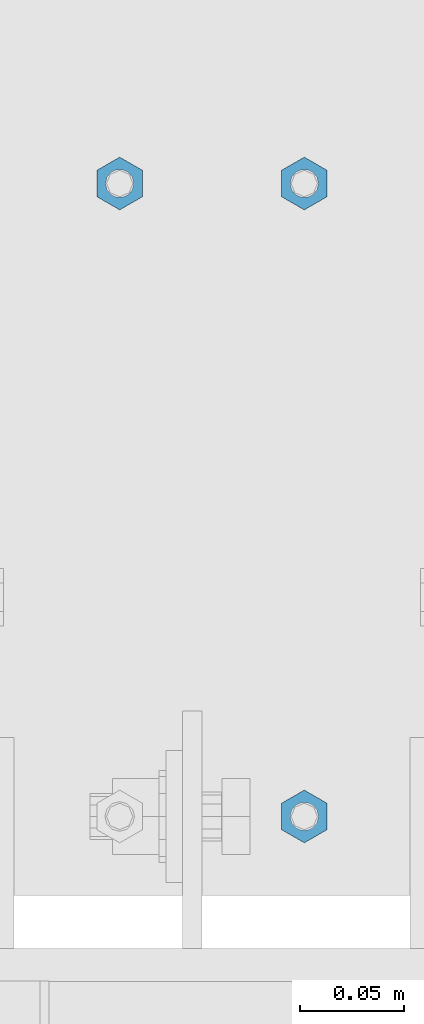
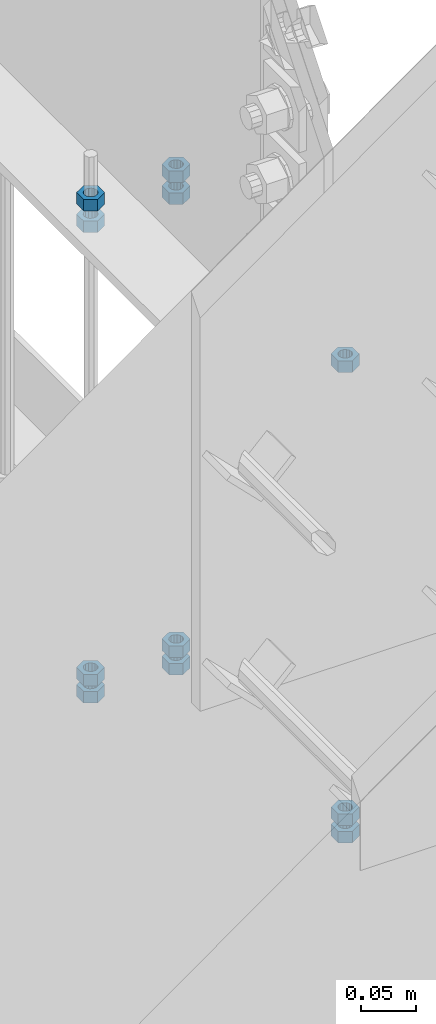
# One storey, part 292 of 975: 11 columns.
"""IFC2X3 building model written with IfcOpenShell, lengths in millimetres."""

import ifcopenshell
import ifcopenshell.guid

model = None  # the IFC model being written
_history = None  # IfcOwnerHistory: only IFC2X3 demands one
_inside = {}  # id of a spatial element -> (the spatial element, [elements in it])
_under = {}  # id of a project, library or spatial element -> (it, [spatial elements below it])
_declared = {}  # id of a project -> (the project, [libraries it declares])
_typed = {}  # id of a type object -> (the type object, [elements of that type])
_made_of = {}  # id of a material, layer set ... -> (it, [elements and type objects made of it])


def new_model(schema):
    """Start an empty IFC model of exactly this schema.

    Asked for "IFC4X3", IfcOpenShell would pick the latest addendum, in which some entities
    have other attributes; the version numbers below select the first issue.
    IFC2X3 requires an IfcOwnerHistory on every rooted entity: one is made here for all.
    """
    global model, _history
    if schema == "IFC4X3":
        model = ifcopenshell.file(schema_version=(4, 3, 0, 0))
    else:
        model = ifcopenshell.file(schema=schema)
    _inside.clear()
    _under.clear()
    _declared.clear()
    _typed.clear()
    _made_of.clear()
    _history = None
    if model.schema == "IFC2X3":
        org = make("IfcOrganization", Name="unknown")
        user = make(
            "IfcPersonAndOrganization",
            ThePerson=make("IfcPerson", FamilyName="unknown"),
            TheOrganization=org,
        )
        app = make(
            "IfcApplication",
            ApplicationDeveloper=org,
            Version="unknown",
            ApplicationFullName="unknown",
            ApplicationIdentifier="unknown",
        )
        _history = make(
            "IfcOwnerHistory",
            OwningUser=user,
            OwningApplication=app,
            ChangeAction="ADDED",
            CreationDate=0,
        )
    return model


def make(cls, **values):
    """One entity of the class cls with the attributes given. An attribute that is None is left unset."""
    return model.create_entity(
        cls, **{name: value for name, value in values.items() if value is not None}
    )


def rooted(cls, **values):
    """An entity with a GlobalId (a new one), such as an element, a storey or a relation."""
    return make(cls, GlobalId=ifcopenshell.guid.new(), OwnerHistory=_history, **values)


def si_unit(unit_type, name, prefix=None):
    """IfcSIUnit, for example si_unit("LENGTHUNIT", "METRE", prefix="MILLI")."""
    return make("IfcSIUnit", UnitType=unit_type, Prefix=prefix, Name=name)


def assignment(units):
    """IfcUnitAssignment: the units of a project."""
    return None if units is None else make("IfcUnitAssignment", Units=units)


def point(xyz):
    """IfcCartesianPoint."""
    return None if xyz is None else make("IfcCartesianPoint", Coordinates=xyz)


def direction(xyz):
    """IfcDirection."""
    return None if xyz is None else make("IfcDirection", DirectionRatios=xyz)


def frame(location, z_axis=None, x_axis=None):
    """IfcAxis2Placement3D, a coordinate frame: its origin and axes. An axis left out is left unset."""
    return make(
        "IfcAxis2Placement3D",
        Location=point(location),
        Axis=direction(z_axis),
        RefDirection=direction(x_axis),
    )


def origin_with_axes():
    """The frame at (0, 0, 0) with the z axis (0, 0, 1) and the x axis (1, 0, 0) written out."""
    return frame((0.0, 0.0, 0.0), z_axis=(0.0, 0.0, 1.0), x_axis=(1.0, 0.0, 0.0))


def place(relative_to, where):
    """IfcLocalPlacement: puts the frame where relative to a parent placement (None: the world)."""
    return make(
        "IfcLocalPlacement", PlacementRelTo=relative_to, RelativePlacement=where
    )


def context(
    kind, dimensions, precision=None, world=None, true_north=None, identifier=None
):
    """IfcGeometricRepresentationContext, for example the 3D "Model" context."""
    return make(
        "IfcGeometricRepresentationContext",
        ContextIdentifier=identifier,
        ContextType=kind,
        CoordinateSpaceDimension=dimensions,
        Precision=precision,
        WorldCoordinateSystem=world,
        TrueNorth=true_north,
    )


def subcontext(parent, identifier, kind, view, scale=None):
    """IfcGeometricRepresentationSubContext, for example "Body" below "Model"."""
    return make(
        "IfcGeometricRepresentationSubContext",
        ContextIdentifier=identifier,
        ContextType=kind,
        ParentContext=parent,
        TargetScale=scale,
        TargetView=view,
    )


def project(units=None, contexts=None):
    """IfcProject with its units and contexts."""
    return rooted(
        "IfcProject",
        Name="project",
        RepresentationContexts=contexts,
        UnitsInContext=assignment(units),
    )


def spatial(cls, under=None, at=None, **own):
    """A site, building, storey or space (cls), placed at a placement, below another one or the project."""
    s = rooted(cls, ObjectPlacement=at, **own)
    if under is not None:
        _under.setdefault(under.id(), (under, []))[1].append(s)
    return s


def faces_of(points, faces, orient=None, outer=None):
    """IfcFace entities. A face is a list of loops; a loop is a list of indices into points, from 0.

    orient and outer hold one flag for each loop. By default every Orientation is true, the
    first loop of a face is its IfcFaceOuterBound and the others are IfcFaceBound.
    """
    made = []
    for i, loops in enumerate(faces):
        bounds = []
        for j, loop in enumerate(loops):
            is_outer = j == 0 if outer is None else outer[i][j]
            bounds.append(
                make(
                    "IfcFaceOuterBound" if is_outer else "IfcFaceBound",
                    Bound=make("IfcPolyLoop", Polygon=[points[k] for k in loop]),
                    Orientation=True if orient is None else orient[i][j],
                )
            )
        made.append(make("IfcFace", Bounds=bounds))
    return made


def faceted_brep(points, faces, orient=None, outer=None, voids=None):
    """IfcFacetedBrep: a solid bounded by flat faces; with voids (closed shells), ...WithVoids."""
    shared = [point(p) for p in points]
    hull = make("IfcClosedShell", CfsFaces=faces_of(shared, faces, orient, outer))
    if voids is None:
        return make("IfcFacetedBrep", Outer=hull)
    return make(
        "IfcFacetedBrepWithVoids",
        Outer=hull,
        Voids=[
            make(cls, CfsFaces=faces_of(shared, fs, o, b)) for cls, fs, o, b in voids
        ],
    )


def shape(context_of_items, identifier, shape_type, items):
    """IfcShapeRepresentation: the items that make up one representation, for example the "Body"."""
    return make(
        "IfcShapeRepresentation",
        ContextOfItems=context_of_items,
        RepresentationIdentifier=identifier,
        RepresentationType=shape_type,
        Items=items,
    )


def material(Name=None, Category=None):
    """IfcMaterial."""
    return make("IfcMaterial", Name=Name, Category=Category)


def made_of(thing, what):
    """Note that an element or type object is made of a material, layer set ...; save() writes the relation."""
    if what is not None:
        _made_of.setdefault(what.id(), (what, []))[1].append(thing)
    return thing


def type_object(cls, material=None, **own):
    """A type object (cls), such as IfcWallType, which elements share."""
    return made_of(rooted(cls, **own), material)


def element(
    cls,
    number,
    at=None,
    inside=None,
    cuts=None,
    type_object=None,
    material=None,
    context=None,
    identifier="Body",
    shape_type=None,
    held_by="IfcProductDefinitionShape",
    body=None,
    shapes=None,
    **own,
):
    """One element of the class cls, such as IfcWall. Its Tag is "e" and its number.

    at: its placement. inside: the storey or other place that contains it. cuts: it is an
    opening in that element (IfcRelVoidsElement). A single representation is given by context,
    identifier, shape_type and body (its items); several are given by shapes. held_by: the class
    of the entity that holds the representations. save() writes the other relations.
    """
    e = rooted(cls, Tag="e%d" % number, ObjectPlacement=at, **own)
    if body is not None:
        shapes = [shape(context, identifier, shape_type, body)]
    if shapes is not None:
        e.Representation = make(held_by, Representations=shapes)
    if inside is not None:
        _inside.setdefault(inside.id(), (inside, []))[1].append(e)
    if cuts is not None:
        rooted(
            "IfcRelVoidsElement", RelatingBuildingElement=cuts, RelatedOpeningElement=e
        )
    if type_object is not None:
        _typed.setdefault(type_object.id(), (type_object, []))[1].append(e)
    return made_of(e, material)


def aggregate(whole, parts):
    """IfcRelAggregates: a whole, such as a stair, and the parts it consists of."""
    return rooted("IfcRelAggregates", RelatingObject=whole, RelatedObjects=parts)


def save(model, path):
    """Write the relations noted so far, then the file.

    IfcRelAggregates (storeys below a building ...), IfcRelContainedInSpatialStructure (elements
    in a storey), IfcRelDefinesByType, IfcRelAssociatesMaterial and IfcRelDeclares: one each for
    every whole, place, type object, material and project.
    """
    for whole, parts in _under.values():
        aggregate(whole, parts)
    for where, things in _inside.values():
        rooted(
            "IfcRelContainedInSpatialStructure",
            RelatedElements=things,
            RelatingStructure=where,
        )
    for kind, things in _typed.values():
        rooted("IfcRelDefinesByType", RelatedObjects=things, RelatingType=kind)
    for what, things in _made_of.values():
        rooted("IfcRelAssociatesMaterial", RelatedObjects=things, RelatingMaterial=what)
    for by, libraries in _declared.values():
        rooted("IfcRelDeclares", RelatingContext=by, RelatedDefinitions=libraries)
    model.write(path)


model = new_model("IFC2X3")

# Units and contexts
model_context = context("Model", 3, precision=1e-05, world=origin_with_axes())
body_context = subcontext(model_context, "Body", "Model", "MODEL_VIEW")
ifc_project = project(units=[si_unit("LENGTHUNIT", "METRE", prefix="MILLI"), si_unit("AREAUNIT", "SQUARE_METRE"), si_unit("VOLUMEUNIT", "CUBIC_METRE"), si_unit("MASSUNIT", "GRAM", prefix="KILO"), si_unit("TIMEUNIT", "SECOND"), si_unit("PLANEANGLEUNIT", "RADIAN"), si_unit("SOLIDANGLEUNIT", "STERADIAN"), si_unit("THERMODYNAMICTEMPERATUREUNIT", "DEGREE_CELSIUS"), si_unit("LUMINOUSINTENSITYUNIT", "LUMEN")], contexts=[model_context])

# Site, building, storey
site_placement = place(None, origin_with_axes())
site = spatial("IfcSite", under=ifc_project, at=site_placement, CompositionType="ELEMENT")
building_placement = place(site_placement, origin_with_axes())
building = spatial("IfcBuilding", under=site, at=building_placement, Name="Undefined", CompositionType="ELEMENT")
storey_placement = place(building_placement, origin_with_axes())
storey = spatial("IfcBuildingStorey", under=building, at=storey_placement, Name="Undefined", CompositionType="ELEMENT", Elevation=0.0)

# Columns
ifc_material = material(Name="STEEL/A307")
column_type = type_object("IfcColumnType", Name="1/2_HEAVY_HEX_NUT", PredefinedType="NOTDEFINED")
column_1_placement = place(storey_placement, frame((8274.05, 21116.925, 2901.95), z_axis=(-0.999999999999998, 6.90000001668524e-08, 0.0), x_axis=(0.0, 0.0, 1.0)))
element("IfcColumn", 1, at=column_1_placement, inside=storey, type_object=column_type, material=ifc_material, Name="NUT", ObjectType="1/2_HEAVY_HEX_NUT", context=body_context, shape_type="Brep", body=[
    faceted_brep([(0.0, -12.6999998092506, -1.09139364212751e-11), (0.0, -6.34999990461802, -11.0000000000218), (12.6999999999998, -6.34999990461802, -11.0000000000218), (12.6999999999998, -12.6999998092506, -1.09139364212751e-11), (0.0, 6.34999990463257, -11.0000000000109), (12.6999999999998, 6.34999990463257, -11.0000000000109), (0.0, 12.6999998092506, 1.09139364212751e-11), (12.6999999999998, 12.6999998092506, 1.09139364212751e-11), (0.0, 6.34999990461802, 11.0000000000218), (12.6999999999998, 6.34999990461802, 11.0000000000218), (0.0, -6.34999990463984, 11.0000000000109), (12.6999999999998, -6.34999990463984, 11.0000000000109), (0.0, -7.27595761418343e-12, 6.75000000000728), (0.0, 2.92871523903523, 6.08153985835088), (12.6999999999998, 2.92871523903523, 6.08153985835088), (12.6999999999998, -7.27595761418343e-12, 6.75000000000728), (0.0, 5.27736250664748, 4.20855616255722), (12.6999999999998, 5.27736250664748, 4.20855616255722), (0.0, 6.58076340721527, 1.50201630420997), (12.6999999999998, 6.58076340721527, 1.50201630420997), (0.0, 6.58076340722255, -1.5020163042027), (12.6999999999998, 6.58076340722255, -1.5020163042027), (0.0, 5.27736250665839, -4.20855616254994), (12.6999999999998, 5.27736250665839, -4.20855616254994), (0.0, 2.92871523904614, -6.08153985834724), (12.6999999999998, 2.92871523904614, -6.08153985834724), (0.0, 3.63797880709171e-12, -6.75000000001273), (12.6999999999998, 3.63797880709171e-12, -6.75000000001273), (0.0, -2.92871523903523, -6.08153985835452), (12.6999999999998, -2.92871523903523, -6.08153985835452), (0.0, -5.27736250665475, -4.20855616255722), (12.6999999999998, -5.27736250665475, -4.20855616255722), (0.0, -6.58076340721891, -1.50201630421179), (12.6999999999998, -6.58076340721891, -1.50201630421179), (0.0, -6.58076340722255, 1.50201630419906), (12.6999999999998, -6.58076340722255, 1.50201630419906), (0.0, -5.27736250665839, 4.20855616254994), (12.6999999999998, -5.27736250665839, 4.20855616254994), (0.0, -2.92871523904614, 6.08153985834724), (12.6999999999998, -2.92871523904614, 6.08153985834724)], [[[0, 1, 2, 3]], [[1, 4, 5, 2]], [[4, 6, 7, 5]], [[6, 8, 9, 7]], [[8, 10, 11, 9]], [[10, 0, 3, 11]], [[12, 13, 14, 15]], [[13, 16, 17, 14]], [[16, 18, 19, 17]], [[18, 20, 21, 19]], [[20, 22, 23, 21]], [[22, 24, 25, 23]], [[24, 26, 27, 25]], [[26, 28, 29, 27]], [[28, 30, 31, 29]], [[30, 32, 33, 31]], [[32, 34, 35, 33]], [[34, 36, 37, 35]], [[36, 38, 39, 37]], [[38, 12, 15, 39]], [[5, 7, 9, 11, 3, 2], [17, 19, 21, 23, 25, 27, 29, 31, 33, 35, 37, 39, 15, 14]], [[10, 8, 6, 4, 1, 0], [38, 36, 34, 32, 30, 28, 26, 24, 22, 20, 18, 16, 13, 12]]]),
])
column_2_placement = place(storey_placement, frame((8274.05, 21116.925, 2882.9), z_axis=(-0.999999999999998, 6.90000001668524e-08, 0.0), x_axis=(0.0, 0.0, 1.0)))
element("IfcColumn", 2, at=column_2_placement, inside=storey, type_object=column_type, material=ifc_material, Name="NUT", ObjectType="1/2_HEAVY_HEX_NUT", context=body_context, shape_type="Brep", body=[
    faceted_brep([(0.0, -12.6999998092506, -1.09139364212751e-11), (0.0, -6.34999990461802, -11.0000000000218), (12.6999999999998, -6.34999990461802, -11.0000000000218), (12.6999999999998, -12.6999998092506, -1.09139364212751e-11), (0.0, 6.34999990463257, -11.0000000000109), (12.6999999999998, 6.34999990463257, -11.0000000000109), (0.0, 12.6999998092506, 1.09139364212751e-11), (12.6999999999998, 12.6999998092506, 1.09139364212751e-11), (0.0, 6.34999990461802, 11.0000000000218), (12.6999999999998, 6.34999990461802, 11.0000000000218), (0.0, -6.34999990463984, 11.0000000000109), (12.6999999999998, -6.34999990463984, 11.0000000000109), (0.0, -7.27595761418343e-12, 6.75000000000728), (0.0, 2.92871523903523, 6.08153985835088), (12.6999999999998, 2.92871523903523, 6.08153985835088), (12.6999999999998, -7.27595761418343e-12, 6.75000000000728), (0.0, 5.27736250664748, 4.20855616255722), (12.6999999999998, 5.27736250664748, 4.20855616255722), (0.0, 6.58076340721527, 1.50201630420997), (12.6999999999998, 6.58076340721527, 1.50201630420997), (0.0, 6.58076340722255, -1.5020163042027), (12.6999999999998, 6.58076340722255, -1.5020163042027), (0.0, 5.27736250665839, -4.20855616254994), (12.6999999999998, 5.27736250665839, -4.20855616254994), (0.0, 2.92871523904614, -6.08153985834724), (12.6999999999998, 2.92871523904614, -6.08153985834724), (0.0, 3.63797880709171e-12, -6.75000000001273), (12.6999999999998, 3.63797880709171e-12, -6.75000000001273), (0.0, -2.92871523903523, -6.08153985835452), (12.6999999999998, -2.92871523903523, -6.08153985835452), (0.0, -5.27736250665475, -4.20855616255722), (12.6999999999998, -5.27736250665475, -4.20855616255722), (0.0, -6.58076340721891, -1.50201630421179), (12.6999999999998, -6.58076340721891, -1.50201630421179), (0.0, -6.58076340722255, 1.50201630419906), (12.6999999999998, -6.58076340722255, 1.50201630419906), (0.0, -5.27736250665839, 4.20855616254994), (12.6999999999998, -5.27736250665839, 4.20855616254994), (0.0, -2.92871523904614, 6.08153985834724), (12.6999999999998, -2.92871523904614, 6.08153985834724)], [[[0, 1, 2, 3]], [[1, 4, 5, 2]], [[4, 6, 7, 5]], [[6, 8, 9, 7]], [[8, 10, 11, 9]], [[10, 0, 3, 11]], [[12, 13, 14, 15]], [[13, 16, 17, 14]], [[16, 18, 19, 17]], [[18, 20, 21, 19]], [[20, 22, 23, 21]], [[22, 24, 25, 23]], [[24, 26, 27, 25]], [[26, 28, 29, 27]], [[28, 30, 31, 29]], [[30, 32, 33, 31]], [[32, 34, 35, 33]], [[34, 36, 37, 35]], [[36, 38, 39, 37]], [[38, 12, 15, 39]], [[5, 7, 9, 11, 3, 2], [17, 19, 21, 23, 25, 27, 29, 31, 33, 35, 37, 39, 15, 14]], [[10, 8, 6, 4, 1, 0], [38, 36, 34, 32, 30, 28, 26, 24, 22, 20, 18, 16, 13, 12]]]),
])
column_3_placement = place(storey_placement, frame((8274.05, 21116.925, 3400.425), z_axis=(-0.999999999999998, 6.90000001668524e-08, 0.0), x_axis=(0.0, 0.0, 1.0)))
element("IfcColumn", 3, at=column_3_placement, inside=storey, type_object=column_type, material=ifc_material, Name="NUT", ObjectType="1/2_HEAVY_HEX_NUT", context=body_context, shape_type="Brep", body=[
    faceted_brep([(0.0, -12.6999998092506, -1.09139364212751e-11), (0.0, -6.34999990461802, -11.0000000000218), (12.6999999999998, -6.34999990461802, -11.0000000000218), (12.6999999999998, -12.6999998092506, -1.09139364212751e-11), (0.0, 6.34999990463257, -11.0000000000109), (12.6999999999998, 6.34999990463257, -11.0000000000109), (0.0, 12.6999998092506, 1.09139364212751e-11), (12.6999999999998, 12.6999998092506, 1.09139364212751e-11), (0.0, 6.34999990461802, 11.0000000000218), (12.6999999999998, 6.34999990461802, 11.0000000000218), (0.0, -6.34999990463984, 11.0000000000109), (12.6999999999998, -6.34999990463984, 11.0000000000109), (0.0, -7.27595761418343e-12, 6.75000000000728), (0.0, 2.92871523903523, 6.08153985835088), (12.6999999999998, 2.92871523903523, 6.08153985835088), (12.6999999999998, -7.27595761418343e-12, 6.75000000000728), (0.0, 5.27736250664748, 4.20855616255722), (12.6999999999998, 5.27736250664748, 4.20855616255722), (0.0, 6.58076340721527, 1.50201630420997), (12.6999999999998, 6.58076340721527, 1.50201630420997), (0.0, 6.58076340722255, -1.5020163042027), (12.6999999999998, 6.58076340722255, -1.5020163042027), (0.0, 5.27736250665839, -4.20855616254994), (12.6999999999998, 5.27736250665839, -4.20855616254994), (0.0, 2.92871523904614, -6.08153985834724), (12.6999999999998, 2.92871523904614, -6.08153985834724), (0.0, 3.63797880709171e-12, -6.75000000001273), (12.6999999999998, 3.63797880709171e-12, -6.75000000001273), (0.0, -2.92871523903523, -6.08153985835452), (12.6999999999998, -2.92871523903523, -6.08153985835452), (0.0, -5.27736250665475, -4.20855616255722), (12.6999999999998, -5.27736250665475, -4.20855616255722), (0.0, -6.58076340721891, -1.50201630421179), (12.6999999999998, -6.58076340721891, -1.50201630421179), (0.0, -6.58076340722255, 1.50201630419906), (12.6999999999998, -6.58076340722255, 1.50201630419906), (0.0, -5.27736250665839, 4.20855616254994), (12.6999999999998, -5.27736250665839, 4.20855616254994), (0.0, -2.92871523904614, 6.08153985834724), (12.6999999999998, -2.92871523904614, 6.08153985834724)], [[[0, 1, 2, 3]], [[1, 4, 5, 2]], [[4, 6, 7, 5]], [[6, 8, 9, 7]], [[8, 10, 11, 9]], [[10, 0, 3, 11]], [[12, 13, 14, 15]], [[13, 16, 17, 14]], [[16, 18, 19, 17]], [[18, 20, 21, 19]], [[20, 22, 23, 21]], [[22, 24, 25, 23]], [[24, 26, 27, 25]], [[26, 28, 29, 27]], [[28, 30, 31, 29]], [[30, 32, 33, 31]], [[32, 34, 35, 33]], [[34, 36, 37, 35]], [[36, 38, 39, 37]], [[38, 12, 15, 39]], [[5, 7, 9, 11, 3, 2], [17, 19, 21, 23, 25, 27, 29, 31, 33, 35, 37, 39, 15, 14]], [[10, 8, 6, 4, 1, 0], [38, 36, 34, 32, 30, 28, 26, 24, 22, 20, 18, 16, 13, 12]]]),
])
column_4_placement = place(storey_placement, frame((8274.05, 21116.925, 3424.2375), z_axis=(-0.999999999999998, 6.90000001668524e-08, 0.0), x_axis=(0.0, 0.0, 1.0)))
element("IfcColumn", 4, at=column_4_placement, inside=storey, type_object=column_type, material=ifc_material, Name="NUT", ObjectType="1/2_HEAVY_HEX_NUT", context=body_context, shape_type="Brep", body=[
    faceted_brep([(0.0, -12.6999998092506, -1.09139364212751e-11), (0.0, -6.34999990461802, -11.0000000000218), (12.6999999999998, -6.34999990461802, -11.0000000000218), (12.6999999999998, -12.6999998092506, -1.09139364212751e-11), (0.0, 6.34999990463257, -11.0000000000109), (12.6999999999998, 6.34999990463257, -11.0000000000109), (0.0, 12.6999998092506, 1.09139364212751e-11), (12.6999999999998, 12.6999998092506, 1.09139364212751e-11), (0.0, 6.34999990461802, 11.0000000000218), (12.6999999999998, 6.34999990461802, 11.0000000000218), (0.0, -6.34999990463984, 11.0000000000109), (12.6999999999998, -6.34999990463984, 11.0000000000109), (0.0, -7.27595761418343e-12, 6.75000000000728), (0.0, 2.92871523903523, 6.08153985835088), (12.6999999999998, 2.92871523903523, 6.08153985835088), (12.6999999999998, -7.27595761418343e-12, 6.75000000000728), (0.0, 5.27736250664748, 4.20855616255722), (12.6999999999998, 5.27736250664748, 4.20855616255722), (0.0, 6.58076340721527, 1.50201630420997), (12.6999999999998, 6.58076340721527, 1.50201630420997), (0.0, 6.58076340722255, -1.5020163042027), (12.6999999999998, 6.58076340722255, -1.5020163042027), (0.0, 5.27736250665839, -4.20855616254994), (12.6999999999998, 5.27736250665839, -4.20855616254994), (0.0, 2.92871523904614, -6.08153985834724), (12.6999999999998, 2.92871523904614, -6.08153985834724), (0.0, 3.63797880709171e-12, -6.75000000001273), (12.6999999999998, 3.63797880709171e-12, -6.75000000001273), (0.0, -2.92871523903523, -6.08153985835452), (12.6999999999998, -2.92871523903523, -6.08153985835452), (0.0, -5.27736250665475, -4.20855616255722), (12.6999999999998, -5.27736250665475, -4.20855616255722), (0.0, -6.58076340721891, -1.50201630421179), (12.6999999999998, -6.58076340721891, -1.50201630421179), (0.0, -6.58076340722255, 1.50201630419906), (12.6999999999998, -6.58076340722255, 1.50201630419906), (0.0, -5.27736250665839, 4.20855616254994), (12.6999999999998, -5.27736250665839, 4.20855616254994), (0.0, -2.92871523904614, 6.08153985834724), (12.6999999999998, -2.92871523904614, 6.08153985834724)], [[[0, 1, 2, 3]], [[1, 4, 5, 2]], [[4, 6, 7, 5]], [[6, 8, 9, 7]], [[8, 10, 11, 9]], [[10, 0, 3, 11]], [[12, 13, 14, 15]], [[13, 16, 17, 14]], [[16, 18, 19, 17]], [[18, 20, 21, 19]], [[20, 22, 23, 21]], [[22, 24, 25, 23]], [[24, 26, 27, 25]], [[26, 28, 29, 27]], [[28, 30, 31, 29]], [[30, 32, 33, 31]], [[32, 34, 35, 33]], [[34, 36, 37, 35]], [[36, 38, 39, 37]], [[38, 12, 15, 39]], [[5, 7, 9, 11, 3, 2], [17, 19, 21, 23, 25, 27, 29, 31, 33, 35, 37, 39, 15, 14]], [[10, 8, 6, 4, 1, 0], [38, 36, 34, 32, 30, 28, 26, 24, 22, 20, 18, 16, 13, 12]]]),
])
column_5_placement = place(storey_placement, frame((8185.15, 21116.925, 2901.95), z_axis=(-0.999999999999998, 6.90000001668524e-08, 0.0), x_axis=(0.0, 0.0, 1.0)))
element("IfcColumn", 5, at=column_5_placement, inside=storey, type_object=column_type, material=ifc_material, Name="NUT", ObjectType="1/2_HEAVY_HEX_NUT", context=body_context, shape_type="Brep", body=[
    faceted_brep([(0.0, -12.6999998092506, -1.09139364212751e-11), (0.0, -6.34999990461802, -11.0000000000218), (12.6999999999998, -6.34999990461802, -11.0000000000218), (12.6999999999998, -12.6999998092506, -1.09139364212751e-11), (0.0, 6.34999990463257, -11.0000000000109), (12.6999999999998, 6.34999990463257, -11.0000000000109), (0.0, 12.6999998092506, 1.09139364212751e-11), (12.6999999999998, 12.6999998092506, 1.09139364212751e-11), (0.0, 6.34999990461802, 11.0000000000218), (12.6999999999998, 6.34999990461802, 11.0000000000218), (0.0, -6.34999990463984, 11.0000000000109), (12.6999999999998, -6.34999990463984, 11.0000000000109), (0.0, -7.27595761418343e-12, 6.75000000000728), (0.0, 2.92871523903523, 6.08153985835088), (12.6999999999998, 2.92871523903523, 6.08153985835088), (12.6999999999998, -7.27595761418343e-12, 6.75000000000728), (0.0, 5.27736250664748, 4.20855616255722), (12.6999999999998, 5.27736250664748, 4.20855616255722), (0.0, 6.58076340721527, 1.50201630420997), (12.6999999999998, 6.58076340721527, 1.50201630420997), (0.0, 6.58076340722255, -1.5020163042027), (12.6999999999998, 6.58076340722255, -1.5020163042027), (0.0, 5.27736250665839, -4.20855616254994), (12.6999999999998, 5.27736250665839, -4.20855616254994), (0.0, 2.92871523904614, -6.08153985834724), (12.6999999999998, 2.92871523904614, -6.08153985834724), (0.0, 3.63797880709171e-12, -6.75000000001273), (12.6999999999998, 3.63797880709171e-12, -6.75000000001273), (0.0, -2.92871523903523, -6.08153985835452), (12.6999999999998, -2.92871523903523, -6.08153985835452), (0.0, -5.27736250665475, -4.20855616255722), (12.6999999999998, -5.27736250665475, -4.20855616255722), (0.0, -6.58076340721891, -1.50201630421179), (12.6999999999998, -6.58076340721891, -1.50201630421179), (0.0, -6.58076340722255, 1.50201630419906), (12.6999999999998, -6.58076340722255, 1.50201630419906), (0.0, -5.27736250665839, 4.20855616254994), (12.6999999999998, -5.27736250665839, 4.20855616254994), (0.0, -2.92871523904614, 6.08153985834724), (12.6999999999998, -2.92871523904614, 6.08153985834724)], [[[0, 1, 2, 3]], [[1, 4, 5, 2]], [[4, 6, 7, 5]], [[6, 8, 9, 7]], [[8, 10, 11, 9]], [[10, 0, 3, 11]], [[12, 13, 14, 15]], [[13, 16, 17, 14]], [[16, 18, 19, 17]], [[18, 20, 21, 19]], [[20, 22, 23, 21]], [[22, 24, 25, 23]], [[24, 26, 27, 25]], [[26, 28, 29, 27]], [[28, 30, 31, 29]], [[30, 32, 33, 31]], [[32, 34, 35, 33]], [[34, 36, 37, 35]], [[36, 38, 39, 37]], [[38, 12, 15, 39]], [[5, 7, 9, 11, 3, 2], [17, 19, 21, 23, 25, 27, 29, 31, 33, 35, 37, 39, 15, 14]], [[10, 8, 6, 4, 1, 0], [38, 36, 34, 32, 30, 28, 26, 24, 22, 20, 18, 16, 13, 12]]]),
])
column_6_placement = place(storey_placement, frame((8185.15, 21116.925, 2882.9), z_axis=(-0.999999999999998, 6.90000001668524e-08, 0.0), x_axis=(0.0, 0.0, 1.0)))
element("IfcColumn", 6, at=column_6_placement, inside=storey, type_object=column_type, material=ifc_material, Name="NUT", ObjectType="1/2_HEAVY_HEX_NUT", context=body_context, shape_type="Brep", body=[
    faceted_brep([(0.0, -12.6999998092506, -1.09139364212751e-11), (0.0, -6.34999990461802, -11.0000000000218), (12.6999999999998, -6.34999990461802, -11.0000000000218), (12.6999999999998, -12.6999998092506, -1.09139364212751e-11), (0.0, 6.34999990463257, -11.0000000000109), (12.6999999999998, 6.34999990463257, -11.0000000000109), (0.0, 12.6999998092506, 1.09139364212751e-11), (12.6999999999998, 12.6999998092506, 1.09139364212751e-11), (0.0, 6.34999990461802, 11.0000000000218), (12.6999999999998, 6.34999990461802, 11.0000000000218), (0.0, -6.34999990463984, 11.0000000000109), (12.6999999999998, -6.34999990463984, 11.0000000000109), (0.0, -7.27595761418343e-12, 6.75000000000728), (0.0, 2.92871523903523, 6.08153985835088), (12.6999999999998, 2.92871523903523, 6.08153985835088), (12.6999999999998, -7.27595761418343e-12, 6.75000000000728), (0.0, 5.27736250664748, 4.20855616255722), (12.6999999999998, 5.27736250664748, 4.20855616255722), (0.0, 6.58076340721527, 1.50201630420997), (12.6999999999998, 6.58076340721527, 1.50201630420997), (0.0, 6.58076340722255, -1.5020163042027), (12.6999999999998, 6.58076340722255, -1.5020163042027), (0.0, 5.27736250665839, -4.20855616254994), (12.6999999999998, 5.27736250665839, -4.20855616254994), (0.0, 2.92871523904614, -6.08153985834724), (12.6999999999998, 2.92871523904614, -6.08153985834724), (0.0, 3.63797880709171e-12, -6.75000000001273), (12.6999999999998, 3.63797880709171e-12, -6.75000000001273), (0.0, -2.92871523903523, -6.08153985835452), (12.6999999999998, -2.92871523903523, -6.08153985835452), (0.0, -5.27736250665475, -4.20855616255722), (12.6999999999998, -5.27736250665475, -4.20855616255722), (0.0, -6.58076340721891, -1.50201630421179), (12.6999999999998, -6.58076340721891, -1.50201630421179), (0.0, -6.58076340722255, 1.50201630419906), (12.6999999999998, -6.58076340722255, 1.50201630419906), (0.0, -5.27736250665839, 4.20855616254994), (12.6999999999998, -5.27736250665839, 4.20855616254994), (0.0, -2.92871523904614, 6.08153985834724), (12.6999999999998, -2.92871523904614, 6.08153985834724)], [[[0, 1, 2, 3]], [[1, 4, 5, 2]], [[4, 6, 7, 5]], [[6, 8, 9, 7]], [[8, 10, 11, 9]], [[10, 0, 3, 11]], [[12, 13, 14, 15]], [[13, 16, 17, 14]], [[16, 18, 19, 17]], [[18, 20, 21, 19]], [[20, 22, 23, 21]], [[22, 24, 25, 23]], [[24, 26, 27, 25]], [[26, 28, 29, 27]], [[28, 30, 31, 29]], [[30, 32, 33, 31]], [[32, 34, 35, 33]], [[34, 36, 37, 35]], [[36, 38, 39, 37]], [[38, 12, 15, 39]], [[5, 7, 9, 11, 3, 2], [17, 19, 21, 23, 25, 27, 29, 31, 33, 35, 37, 39, 15, 14]], [[10, 8, 6, 4, 1, 0], [38, 36, 34, 32, 30, 28, 26, 24, 22, 20, 18, 16, 13, 12]]]),
])
column_7_placement = place(storey_placement, frame((8185.15, 21116.925, 3400.425), z_axis=(-0.999999999999998, 6.90000001668524e-08, 0.0), x_axis=(0.0, 0.0, 1.0)))
element("IfcColumn", 7, at=column_7_placement, inside=storey, type_object=column_type, material=ifc_material, Name="NUT", ObjectType="1/2_HEAVY_HEX_NUT", context=body_context, shape_type="Brep", body=[
    faceted_brep([(0.0, -12.6999998092506, -1.09139364212751e-11), (0.0, -6.34999990461802, -11.0000000000218), (12.6999999999998, -6.34999990461802, -11.0000000000218), (12.6999999999998, -12.6999998092506, -1.09139364212751e-11), (0.0, 6.34999990463257, -11.0000000000109), (12.6999999999998, 6.34999990463257, -11.0000000000109), (0.0, 12.6999998092506, 1.09139364212751e-11), (12.6999999999998, 12.6999998092506, 1.09139364212751e-11), (0.0, 6.34999990461802, 11.0000000000218), (12.6999999999998, 6.34999990461802, 11.0000000000218), (0.0, -6.34999990463984, 11.0000000000109), (12.6999999999998, -6.34999990463984, 11.0000000000109), (0.0, -7.27595761418343e-12, 6.75000000000728), (0.0, 2.92871523903523, 6.08153985835088), (12.6999999999998, 2.92871523903523, 6.08153985835088), (12.6999999999998, -7.27595761418343e-12, 6.75000000000728), (0.0, 5.27736250664748, 4.20855616255722), (12.6999999999998, 5.27736250664748, 4.20855616255722), (0.0, 6.58076340721527, 1.50201630420997), (12.6999999999998, 6.58076340721527, 1.50201630420997), (0.0, 6.58076340722255, -1.5020163042027), (12.6999999999998, 6.58076340722255, -1.5020163042027), (0.0, 5.27736250665839, -4.20855616254994), (12.6999999999998, 5.27736250665839, -4.20855616254994), (0.0, 2.92871523904614, -6.08153985834724), (12.6999999999998, 2.92871523904614, -6.08153985834724), (0.0, 3.63797880709171e-12, -6.75000000001273), (12.6999999999998, 3.63797880709171e-12, -6.75000000001273), (0.0, -2.92871523903523, -6.08153985835452), (12.6999999999998, -2.92871523903523, -6.08153985835452), (0.0, -5.27736250665475, -4.20855616255722), (12.6999999999998, -5.27736250665475, -4.20855616255722), (0.0, -6.58076340721891, -1.50201630421179), (12.6999999999998, -6.58076340721891, -1.50201630421179), (0.0, -6.58076340722255, 1.50201630419906), (12.6999999999998, -6.58076340722255, 1.50201630419906), (0.0, -5.27736250665839, 4.20855616254994), (12.6999999999998, -5.27736250665839, 4.20855616254994), (0.0, -2.92871523904614, 6.08153985834724), (12.6999999999998, -2.92871523904614, 6.08153985834724)], [[[0, 1, 2, 3]], [[1, 4, 5, 2]], [[4, 6, 7, 5]], [[6, 8, 9, 7]], [[8, 10, 11, 9]], [[10, 0, 3, 11]], [[12, 13, 14, 15]], [[13, 16, 17, 14]], [[16, 18, 19, 17]], [[18, 20, 21, 19]], [[20, 22, 23, 21]], [[22, 24, 25, 23]], [[24, 26, 27, 25]], [[26, 28, 29, 27]], [[28, 30, 31, 29]], [[30, 32, 33, 31]], [[32, 34, 35, 33]], [[34, 36, 37, 35]], [[36, 38, 39, 37]], [[38, 12, 15, 39]], [[5, 7, 9, 11, 3, 2], [17, 19, 21, 23, 25, 27, 29, 31, 33, 35, 37, 39, 15, 14]], [[10, 8, 6, 4, 1, 0], [38, 36, 34, 32, 30, 28, 26, 24, 22, 20, 18, 16, 13, 12]]]),
])
column_8_placement = place(storey_placement, frame((8185.15, 21116.925, 3424.2375), z_axis=(-0.999999999999998, 6.90000001668524e-08, 0.0), x_axis=(0.0, 0.0, 1.0)))
element("IfcColumn", 8, at=column_8_placement, inside=storey, type_object=column_type, material=ifc_material, Name="NUT", ObjectType="1/2_HEAVY_HEX_NUT", context=body_context, shape_type="Brep", body=[
    faceted_brep([(0.0, -12.6999998092506, -1.09139364212751e-11), (0.0, -6.34999990461802, -11.0000000000218), (12.6999999999998, -6.34999990461802, -11.0000000000218), (12.6999999999998, -12.6999998092506, -1.09139364212751e-11), (0.0, 6.34999990463257, -11.0000000000109), (12.6999999999998, 6.34999990463257, -11.0000000000109), (0.0, 12.6999998092506, 1.09139364212751e-11), (12.6999999999998, 12.6999998092506, 1.09139364212751e-11), (0.0, 6.34999990461802, 11.0000000000218), (12.6999999999998, 6.34999990461802, 11.0000000000218), (0.0, -6.34999990463984, 11.0000000000109), (12.6999999999998, -6.34999990463984, 11.0000000000109), (0.0, -7.27595761418343e-12, 6.75000000000728), (0.0, 2.92871523903523, 6.08153985835088), (12.6999999999998, 2.92871523903523, 6.08153985835088), (12.6999999999998, -7.27595761418343e-12, 6.75000000000728), (0.0, 5.27736250664748, 4.20855616255722), (12.6999999999998, 5.27736250664748, 4.20855616255722), (0.0, 6.58076340721527, 1.50201630420997), (12.6999999999998, 6.58076340721527, 1.50201630420997), (0.0, 6.58076340722255, -1.5020163042027), (12.6999999999998, 6.58076340722255, -1.5020163042027), (0.0, 5.27736250665839, -4.20855616254994), (12.6999999999998, 5.27736250665839, -4.20855616254994), (0.0, 2.92871523904614, -6.08153985834724), (12.6999999999998, 2.92871523904614, -6.08153985834724), (0.0, 3.63797880709171e-12, -6.75000000001273), (12.6999999999998, 3.63797880709171e-12, -6.75000000001273), (0.0, -2.92871523903523, -6.08153985835452), (12.6999999999998, -2.92871523903523, -6.08153985835452), (0.0, -5.27736250665475, -4.20855616255722), (12.6999999999998, -5.27736250665475, -4.20855616255722), (0.0, -6.58076340721891, -1.50201630421179), (12.6999999999998, -6.58076340721891, -1.50201630421179), (0.0, -6.58076340722255, 1.50201630419906), (12.6999999999998, -6.58076340722255, 1.50201630419906), (0.0, -5.27736250665839, 4.20855616254994), (12.6999999999998, -5.27736250665839, 4.20855616254994), (0.0, -2.92871523904614, 6.08153985834724), (12.6999999999998, -2.92871523904614, 6.08153985834724)], [[[0, 1, 2, 3]], [[1, 4, 5, 2]], [[4, 6, 7, 5]], [[6, 8, 9, 7]], [[8, 10, 11, 9]], [[10, 0, 3, 11]], [[12, 13, 14, 15]], [[13, 16, 17, 14]], [[16, 18, 19, 17]], [[18, 20, 21, 19]], [[20, 22, 23, 21]], [[22, 24, 25, 23]], [[24, 26, 27, 25]], [[26, 28, 29, 27]], [[28, 30, 31, 29]], [[30, 32, 33, 31]], [[32, 34, 35, 33]], [[34, 36, 37, 35]], [[36, 38, 39, 37]], [[38, 12, 15, 39]], [[5, 7, 9, 11, 3, 2], [17, 19, 21, 23, 25, 27, 29, 31, 33, 35, 37, 39, 15, 14]], [[10, 8, 6, 4, 1, 0], [38, 36, 34, 32, 30, 28, 26, 24, 22, 20, 18, 16, 13, 12]]]),
])
column_9_placement = place(storey_placement, frame((8274.05, 20812.125, 2901.95), z_axis=(-0.999999999999998, 6.90000001668524e-08, 0.0), x_axis=(0.0, 0.0, 1.0)))
element("IfcColumn", 9, at=column_9_placement, inside=storey, type_object=column_type, material=ifc_material, Name="NUT", ObjectType="1/2_HEAVY_HEX_NUT", context=body_context, shape_type="Brep", body=[
    faceted_brep([(0.0, -12.6999998092506, -1.09139364212751e-11), (0.0, -6.34999990461802, -11.0000000000218), (12.6999999999998, -6.34999990461802, -11.0000000000218), (12.6999999999998, -12.6999998092506, -1.09139364212751e-11), (0.0, 6.34999990463257, -11.0000000000109), (12.6999999999998, 6.34999990463257, -11.0000000000109), (0.0, 12.6999998092506, 1.09139364212751e-11), (12.6999999999998, 12.6999998092506, 1.09139364212751e-11), (0.0, 6.34999990461802, 11.0000000000218), (12.6999999999998, 6.34999990461802, 11.0000000000218), (0.0, -6.34999990463984, 11.0000000000109), (12.6999999999998, -6.34999990463984, 11.0000000000109), (0.0, -7.27595761418343e-12, 6.75000000000728), (0.0, 2.92871523903523, 6.08153985835088), (12.6999999999998, 2.92871523903523, 6.08153985835088), (12.6999999999998, -7.27595761418343e-12, 6.75000000000728), (0.0, 5.27736250664748, 4.20855616255722), (12.6999999999998, 5.27736250664748, 4.20855616255722), (0.0, 6.58076340721527, 1.50201630420997), (12.6999999999998, 6.58076340721527, 1.50201630420997), (0.0, 6.58076340722255, -1.5020163042027), (12.6999999999998, 6.58076340722255, -1.5020163042027), (0.0, 5.27736250665839, -4.20855616254994), (12.6999999999998, 5.27736250665839, -4.20855616254994), (0.0, 2.92871523904614, -6.08153985834724), (12.6999999999998, 2.92871523904614, -6.08153985834724), (0.0, 3.63797880709171e-12, -6.75000000001273), (12.6999999999998, 3.63797880709171e-12, -6.75000000001273), (0.0, -2.92871523903523, -6.08153985835452), (12.6999999999998, -2.92871523903523, -6.08153985835452), (0.0, -5.27736250665475, -4.20855616255722), (12.6999999999998, -5.27736250665475, -4.20855616255722), (0.0, -6.58076340721891, -1.50201630421179), (12.6999999999998, -6.58076340721891, -1.50201630421179), (0.0, -6.58076340722255, 1.50201630419906), (12.6999999999998, -6.58076340722255, 1.50201630419906), (0.0, -5.27736250665839, 4.20855616254994), (12.6999999999998, -5.27736250665839, 4.20855616254994), (0.0, -2.92871523904614, 6.08153985834724), (12.6999999999998, -2.92871523904614, 6.08153985834724)], [[[0, 1, 2, 3]], [[1, 4, 5, 2]], [[4, 6, 7, 5]], [[6, 8, 9, 7]], [[8, 10, 11, 9]], [[10, 0, 3, 11]], [[12, 13, 14, 15]], [[13, 16, 17, 14]], [[16, 18, 19, 17]], [[18, 20, 21, 19]], [[20, 22, 23, 21]], [[22, 24, 25, 23]], [[24, 26, 27, 25]], [[26, 28, 29, 27]], [[28, 30, 31, 29]], [[30, 32, 33, 31]], [[32, 34, 35, 33]], [[34, 36, 37, 35]], [[36, 38, 39, 37]], [[38, 12, 15, 39]], [[5, 7, 9, 11, 3, 2], [17, 19, 21, 23, 25, 27, 29, 31, 33, 35, 37, 39, 15, 14]], [[10, 8, 6, 4, 1, 0], [38, 36, 34, 32, 30, 28, 26, 24, 22, 20, 18, 16, 13, 12]]]),
])
column_10_placement = place(storey_placement, frame((8274.05, 20812.125, 2882.9), z_axis=(-0.999999999999998, 6.90000001668524e-08, 0.0), x_axis=(0.0, 0.0, 1.0)))
element("IfcColumn", 10, at=column_10_placement, inside=storey, type_object=column_type, material=ifc_material, Name="NUT", ObjectType="1/2_HEAVY_HEX_NUT", context=body_context, shape_type="Brep", body=[
    faceted_brep([(0.0, -12.6999998092506, -1.09139364212751e-11), (0.0, -6.34999990461802, -11.0000000000218), (12.6999999999998, -6.34999990461802, -11.0000000000218), (12.6999999999998, -12.6999998092506, -1.09139364212751e-11), (0.0, 6.34999990463257, -11.0000000000109), (12.6999999999998, 6.34999990463257, -11.0000000000109), (0.0, 12.6999998092506, 1.09139364212751e-11), (12.6999999999998, 12.6999998092506, 1.09139364212751e-11), (0.0, 6.34999990461802, 11.0000000000218), (12.6999999999998, 6.34999990461802, 11.0000000000218), (0.0, -6.34999990463984, 11.0000000000109), (12.6999999999998, -6.34999990463984, 11.0000000000109), (0.0, -7.27595761418343e-12, 6.75000000000728), (0.0, 2.92871523903523, 6.08153985835088), (12.6999999999998, 2.92871523903523, 6.08153985835088), (12.6999999999998, -7.27595761418343e-12, 6.75000000000728), (0.0, 5.27736250664748, 4.20855616255722), (12.6999999999998, 5.27736250664748, 4.20855616255722), (0.0, 6.58076340721527, 1.50201630420997), (12.6999999999998, 6.58076340721527, 1.50201630420997), (0.0, 6.58076340722255, -1.5020163042027), (12.6999999999998, 6.58076340722255, -1.5020163042027), (0.0, 5.27736250665839, -4.20855616254994), (12.6999999999998, 5.27736250665839, -4.20855616254994), (0.0, 2.92871523904614, -6.08153985834724), (12.6999999999998, 2.92871523904614, -6.08153985834724), (0.0, 3.63797880709171e-12, -6.75000000001273), (12.6999999999998, 3.63797880709171e-12, -6.75000000001273), (0.0, -2.92871523903523, -6.08153985835452), (12.6999999999998, -2.92871523903523, -6.08153985835452), (0.0, -5.27736250665475, -4.20855616255722), (12.6999999999998, -5.27736250665475, -4.20855616255722), (0.0, -6.58076340721891, -1.50201630421179), (12.6999999999998, -6.58076340721891, -1.50201630421179), (0.0, -6.58076340722255, 1.50201630419906), (12.6999999999998, -6.58076340722255, 1.50201630419906), (0.0, -5.27736250665839, 4.20855616254994), (12.6999999999998, -5.27736250665839, 4.20855616254994), (0.0, -2.92871523904614, 6.08153985834724), (12.6999999999998, -2.92871523904614, 6.08153985834724)], [[[0, 1, 2, 3]], [[1, 4, 5, 2]], [[4, 6, 7, 5]], [[6, 8, 9, 7]], [[8, 10, 11, 9]], [[10, 0, 3, 11]], [[12, 13, 14, 15]], [[13, 16, 17, 14]], [[16, 18, 19, 17]], [[18, 20, 21, 19]], [[20, 22, 23, 21]], [[22, 24, 25, 23]], [[24, 26, 27, 25]], [[26, 28, 29, 27]], [[28, 30, 31, 29]], [[30, 32, 33, 31]], [[32, 34, 35, 33]], [[34, 36, 37, 35]], [[36, 38, 39, 37]], [[38, 12, 15, 39]], [[5, 7, 9, 11, 3, 2], [17, 19, 21, 23, 25, 27, 29, 31, 33, 35, 37, 39, 15, 14]], [[10, 8, 6, 4, 1, 0], [38, 36, 34, 32, 30, 28, 26, 24, 22, 20, 18, 16, 13, 12]]]),
])
column_11_placement = place(storey_placement, frame((8274.05, 20812.125, 3400.425), z_axis=(-0.999999999999998, 6.90000001668524e-08, 0.0), x_axis=(0.0, 0.0, 1.0)))
element("IfcColumn", 11, at=column_11_placement, inside=storey, type_object=column_type, material=ifc_material, Name="NUT", ObjectType="1/2_HEAVY_HEX_NUT", context=body_context, shape_type="Brep", body=[
    faceted_brep([(0.0, -12.6999998092506, -1.09139364212751e-11), (0.0, -6.34999990461802, -11.0000000000218), (12.6999999999998, -6.34999990461802, -11.0000000000218), (12.6999999999998, -12.6999998092506, -1.09139364212751e-11), (0.0, 6.34999990463257, -11.0000000000109), (12.6999999999998, 6.34999990463257, -11.0000000000109), (0.0, 12.6999998092506, 1.09139364212751e-11), (12.6999999999998, 12.6999998092506, 1.09139364212751e-11), (0.0, 6.34999990461802, 11.0000000000218), (12.6999999999998, 6.34999990461802, 11.0000000000218), (0.0, -6.34999990463984, 11.0000000000109), (12.6999999999998, -6.34999990463984, 11.0000000000109), (0.0, -7.27595761418343e-12, 6.75000000000728), (0.0, 2.92871523903523, 6.08153985835088), (12.6999999999998, 2.92871523903523, 6.08153985835088), (12.6999999999998, -7.27595761418343e-12, 6.75000000000728), (0.0, 5.27736250664748, 4.20855616255722), (12.6999999999998, 5.27736250664748, 4.20855616255722), (0.0, 6.58076340721527, 1.50201630420997), (12.6999999999998, 6.58076340721527, 1.50201630420997), (0.0, 6.58076340722255, -1.5020163042027), (12.6999999999998, 6.58076340722255, -1.5020163042027), (0.0, 5.27736250665839, -4.20855616254994), (12.6999999999998, 5.27736250665839, -4.20855616254994), (0.0, 2.92871523904614, -6.08153985834724), (12.6999999999998, 2.92871523904614, -6.08153985834724), (0.0, 3.63797880709171e-12, -6.75000000001273), (12.6999999999998, 3.63797880709171e-12, -6.75000000001273), (0.0, -2.92871523903523, -6.08153985835452), (12.6999999999998, -2.92871523903523, -6.08153985835452), (0.0, -5.27736250665475, -4.20855616255722), (12.6999999999998, -5.27736250665475, -4.20855616255722), (0.0, -6.58076340721891, -1.50201630421179), (12.6999999999998, -6.58076340721891, -1.50201630421179), (0.0, -6.58076340722255, 1.50201630419906), (12.6999999999998, -6.58076340722255, 1.50201630419906), (0.0, -5.27736250665839, 4.20855616254994), (12.6999999999998, -5.27736250665839, 4.20855616254994), (0.0, -2.92871523904614, 6.08153985834724), (12.6999999999998, -2.92871523904614, 6.08153985834724)], [[[0, 1, 2, 3]], [[1, 4, 5, 2]], [[4, 6, 7, 5]], [[6, 8, 9, 7]], [[8, 10, 11, 9]], [[10, 0, 3, 11]], [[12, 13, 14, 15]], [[13, 16, 17, 14]], [[16, 18, 19, 17]], [[18, 20, 21, 19]], [[20, 22, 23, 21]], [[22, 24, 25, 23]], [[24, 26, 27, 25]], [[26, 28, 29, 27]], [[28, 30, 31, 29]], [[30, 32, 33, 31]], [[32, 34, 35, 33]], [[34, 36, 37, 35]], [[36, 38, 39, 37]], [[38, 12, 15, 39]], [[5, 7, 9, 11, 3, 2], [17, 19, 21, 23, 25, 27, 29, 31, 33, 35, 37, 39, 15, 14]], [[10, 8, 6, 4, 1, 0], [38, 36, 34, 32, 30, 28, 26, 24, 22, 20, 18, 16, 13, 12]]]),
])

save(model, "model.ifc")
